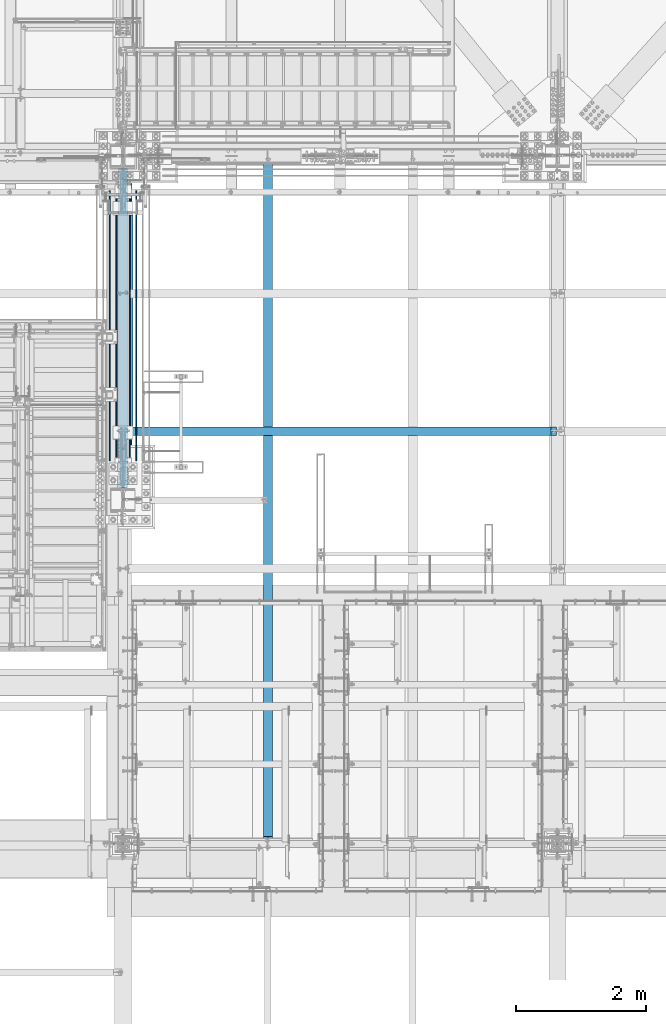
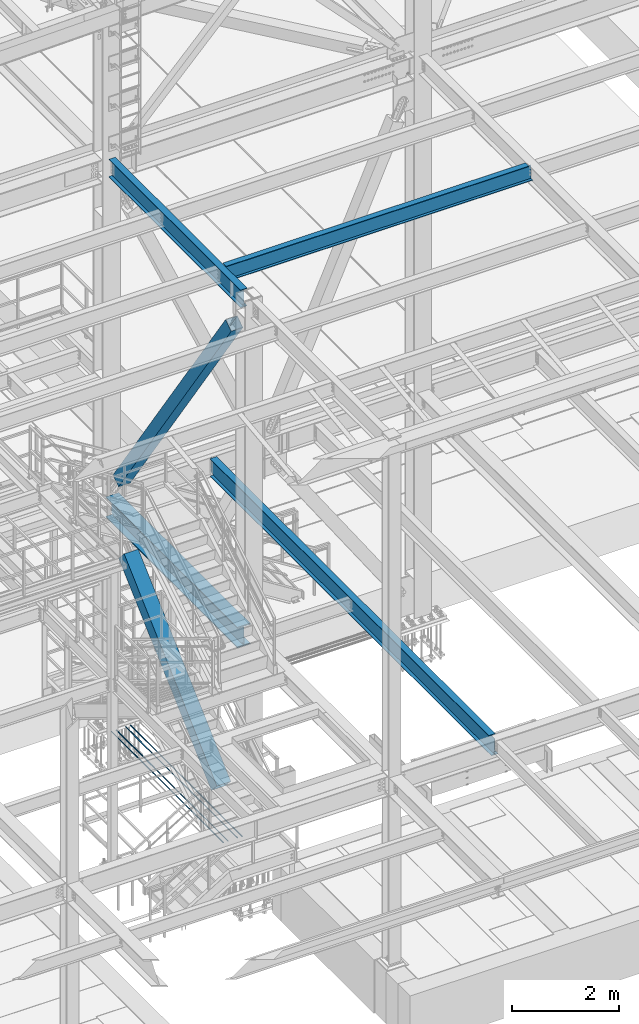
# One storey, part 1777 of 3843: 8 beams, 2 members, 10 elements without a shape of their own.
"""IFC2X3 building model written with IfcOpenShell, lengths in millimetres."""

from ifc_helpers import new_model, si_unit, frame, origin_with_axes, place, context, subcontext, project, spatial, faceted_brep, material, type_object, element, aggregate, save


model = new_model("IFC2X3")

# Units and contexts
model_context = context("Model", 3, precision=1e-05, world=origin_with_axes())
body_context = subcontext(model_context, "Body", "Model", "MODEL_VIEW")
ifc_project = project(units=[si_unit("LENGTHUNIT", "METRE", prefix="MILLI"), si_unit("AREAUNIT", "SQUARE_METRE"), si_unit("VOLUMEUNIT", "CUBIC_METRE"), si_unit("MASSUNIT", "GRAM", prefix="KILO"), si_unit("TIMEUNIT", "SECOND"), si_unit("PLANEANGLEUNIT", "RADIAN"), si_unit("SOLIDANGLEUNIT", "STERADIAN"), si_unit("THERMODYNAMICTEMPERATUREUNIT", "DEGREE_CELSIUS"), si_unit("LUMINOUSINTENSITYUNIT", "LUMEN")], contexts=[model_context])

# Site, building, storey
site_placement = place(None, origin_with_axes())
site = spatial("IfcSite", under=ifc_project, at=site_placement, CompositionType="ELEMENT")
building_placement = place(site_placement, origin_with_axes())
building = spatial("IfcBuilding", under=site, at=building_placement, Name="Undefined", CompositionType="ELEMENT")
storey_placement = place(building_placement, origin_with_axes())
storey = spatial("IfcBuildingStorey", under=building, at=storey_placement, Name="Undefined", CompositionType="ELEMENT", Elevation=0.0)

# Assembly, beam
assembly_1_placement = place(storey_placement, origin_with_axes())
assembly_1 = element("IfcElementAssembly", 1, at=assembly_1_placement, inside=storey, Name="REBAR", AssemblyPlace="NOTDEFINED", PredefinedType="RIGID_FRAME")
ifc_material_1 = material(Name="STEEL/A706-60")
beam_type_1 = type_object("IfcBeamType", Name="#10 REBAR", PredefinedType="NOTDEFINED")
beam_1_placement = place(assembly_1_placement, frame((55727.6, 25082.5, 29687.8375), z_axis=(0.0, 0.0, 1.0), x_axis=(0.0, -1.0, 0.0)))
beam_1 = element("IfcBeam", 2, at=beam_1_placement, type_object=beam_type_1, material=ifc_material_1, Name="REBAR", ObjectType="#10 REBAR", context=body_context, shape_type="Brep", body=[
    faceted_brep([(0.0, -7.9375, 0.0), (0.0, -5.61266007566883, -5.61266007566883), (4165.68743163327, -5.61266007566883, -5.61266007566883), (4165.68743163327, -7.9375, 0.0), (0.0, 0.0, -7.9375), (4165.68743163327, 0.0, -7.9375), (0.0, 5.61266007566883, -5.61266007566883), (4165.68743163327, 5.61266007566883, -5.61266007566883), (0.0, 7.9375, 0.0), (4165.68743163327, 7.9375, 0.0), (0.0, 5.61266007566883, 5.61266007566883), (4165.68743163327, 5.61266007566883, 5.61266007566883), (0.0, 0.0, 7.9375), (4165.68743163327, 0.0, 7.9375), (0.0, -5.61266007566883, 5.61266007566883), (4165.68743163327, -5.61266007566883, 5.61266007566883)], [[[0, 1, 2, 3]], [[1, 4, 5, 2]], [[4, 6, 7, 5]], [[6, 8, 9, 7]], [[8, 10, 11, 9]], [[10, 12, 13, 11]], [[12, 14, 15, 13]], [[14, 0, 3, 15]], [[5, 7, 9, 11, 13, 15, 3, 2]], [[14, 12, 10, 8, 6, 4, 1, 0]]]),
])
aggregate(assembly_1, [beam_1])

assembly_2_placement = place(storey_placement, origin_with_axes())
assembly_2 = element("IfcElementAssembly", 3, at=assembly_2_placement, inside=storey, Name="REBAR", AssemblyPlace="NOTDEFINED", PredefinedType="RIGID_FRAME")
beam_2_placement = place(assembly_2_placement, frame((55829.2, 25082.5, 29687.8375), z_axis=(0.0, 0.0, 1.0), x_axis=(0.0, -1.0, 0.0)))
beam_2 = element("IfcBeam", 4, at=beam_2_placement, type_object=beam_type_1, material=ifc_material_1, Name="REBAR", ObjectType="#10 REBAR", context=body_context, shape_type="Brep", body=[
    faceted_brep([(0.0, -7.9375, 0.0), (0.0, -5.61266007566883, -5.61266007566883), (4165.68743163327, -5.61266007566883, -5.61266007566883), (4165.68743163327, -7.9375, 0.0), (0.0, 0.0, -7.9375), (4165.68743163327, 0.0, -7.9375), (0.0, 5.61266007566883, -5.61266007566883), (4165.68743163327, 5.61266007566883, -5.61266007566883), (0.0, 7.9375, 0.0), (4165.68743163327, 7.9375, 0.0), (0.0, 5.61266007566883, 5.61266007566883), (4165.68743163327, 5.61266007566883, 5.61266007566883), (0.0, 0.0, 7.9375), (4165.68743163327, 0.0, 7.9375), (0.0, -5.61266007566883, 5.61266007566883), (4165.68743163327, -5.61266007566883, 5.61266007566883)], [[[0, 1, 2, 3]], [[1, 4, 5, 2]], [[4, 6, 7, 5]], [[6, 8, 9, 7]], [[8, 10, 11, 9]], [[10, 12, 13, 11]], [[12, 14, 15, 13]], [[14, 0, 3, 15]], [[5, 7, 9, 11, 13, 15, 3, 2]], [[14, 12, 10, 8, 6, 4, 1, 0]]]),
])
aggregate(assembly_2, [beam_2])

assembly_3_placement = place(storey_placement, origin_with_axes())
assembly_3 = element("IfcElementAssembly", 5, at=assembly_3_placement, inside=storey, Name="REBAR", AssemblyPlace="NOTDEFINED", PredefinedType="RIGID_FRAME")
beam_3_placement = place(assembly_3_placement, frame((56032.4, 25082.5, 29687.8375), z_axis=(0.0, 0.0, 1.0), x_axis=(0.0, -1.0, 0.0)))
beam_3 = element("IfcBeam", 6, at=beam_3_placement, type_object=beam_type_1, material=ifc_material_1, Name="REBAR", ObjectType="#10 REBAR", context=body_context, shape_type="Brep", body=[
    faceted_brep([(0.0, -7.9375, 0.0), (0.0, -5.61266007566883, -5.61266007566883), (4165.68743163327, -5.61266007566883, -5.61266007566883), (4165.68743163327, -7.9375, 0.0), (0.0, 0.0, -7.9375), (4165.68743163327, 0.0, -7.9375), (0.0, 5.61266007566883, -5.61266007566883), (4165.68743163327, 5.61266007566883, -5.61266007566883), (0.0, 7.9375, 0.0), (4165.68743163327, 7.9375, 0.0), (0.0, 5.61266007566883, 5.61266007566883), (4165.68743163327, 5.61266007566883, 5.61266007566883), (0.0, 0.0, 7.9375), (4165.68743163327, 0.0, 7.9375), (0.0, -5.61266007566883, 5.61266007566883), (4165.68743163327, -5.61266007566883, 5.61266007566883)], [[[0, 1, 2, 3]], [[1, 4, 5, 2]], [[4, 6, 7, 5]], [[6, 8, 9, 7]], [[8, 10, 11, 9]], [[10, 12, 13, 11]], [[12, 14, 15, 13]], [[14, 0, 3, 15]], [[5, 7, 9, 11, 13, 15, 3, 2]], [[14, 12, 10, 8, 6, 4, 1, 0]]]),
])
aggregate(assembly_3, [beam_3])

assembly_4_placement = place(storey_placement, origin_with_axes())
assembly_4 = element("IfcElementAssembly", 7, at=assembly_4_placement, inside=storey, Name="REBAR", AssemblyPlace="NOTDEFINED", PredefinedType="RIGID_FRAME")
beam_4_placement = place(assembly_4_placement, frame((56134.0, 25082.5, 29687.8375), z_axis=(0.0, 0.0, 1.0), x_axis=(0.0, -1.0, 0.0)))
beam_4 = element("IfcBeam", 8, at=beam_4_placement, type_object=beam_type_1, material=ifc_material_1, Name="REBAR", ObjectType="#10 REBAR", context=body_context, shape_type="Brep", body=[
    faceted_brep([(0.0, -7.9375, 0.0), (0.0, -5.61266007566883, -5.61266007566883), (4165.68743163327, -5.61266007566883, -5.61266007566883), (4165.68743163327, -7.9375, 0.0), (0.0, 0.0, -7.9375), (4165.68743163327, 0.0, -7.9375), (0.0, 5.61266007566883, -5.61266007566883), (4165.68743163327, 5.61266007566883, -5.61266007566883), (0.0, 7.9375, 0.0), (4165.68743163327, 7.9375, 0.0), (0.0, 5.61266007566883, 5.61266007566883), (4165.68743163327, 5.61266007566883, 5.61266007566883), (0.0, 0.0, 7.9375), (4165.68743163327, 0.0, 7.9375), (0.0, -5.61266007566883, 5.61266007566883), (4165.68743163327, -5.61266007566883, 5.61266007566883)], [[[0, 1, 2, 3]], [[1, 4, 5, 2]], [[4, 6, 7, 5]], [[6, 8, 9, 7]], [[8, 10, 11, 9]], [[10, 12, 13, 11]], [[12, 14, 15, 13]], [[14, 0, 3, 15]], [[5, 7, 9, 11, 13, 15, 3, 2]], [[14, 12, 10, 8, 6, 4, 1, 0]]]),
])
aggregate(assembly_4, [beam_4])

# Assembly, member
assembly_5_placement = place(storey_placement, origin_with_axes())
assembly_5 = element("IfcElementAssembly", 9, at=assembly_5_placement, inside=storey, Name="None", AssemblyPlace="NOTDEFINED", PredefinedType="RIGID_FRAME")
ifc_material_2 = material(Name="STEEL/A992")
member_type_1 = type_object("IfcMemberType", Name="HSS10X10X1/4", PredefinedType="NOTDEFINED")
member_1_placement = place(assembly_5_placement, frame((55930.8, 25062.0648839254, 35381.0757645592), z_axis=(-1.0, 0.0, 0.0), x_axis=(0.0, -0.56819627680556, 0.82289306171841)))
member_1 = element("IfcMember", 10, at=member_1_placement, type_object=member_type_1, material=ifc_material_2, Name="None", ObjectType="HSS10X10X1/4", context=body_context, shape_type="Brep", body=[
    faceted_brep([(2.00088834390044e-10, 120.650000000089, -120.649999999994), (-2.03726813197136e-10, -120.650000000081, -120.649999999994), (7397.75000004993, -120.650000005451, -120.650000000001), (7397.7500000501, 120.649999994785, -120.650000000001), (-2.03726813197136e-10, -120.650000000081, 120.649999999994), (7397.75000004993, -120.650000005451, 120.650000000001), (2.00088834390044e-10, 120.650000000089, 120.649999999994), (7397.7500000501, 120.649999994785, 120.650000000001), (2.16459739021957e-10, 127.000000000087, -127.0), (2.16459739021957e-10, 127.000000000087, 127.0), (7397.75000005011, 126.99999999479, 127.0), (7397.75000005011, 126.99999999479, -127.0), (-2.14640749618411e-10, -127.00000000008, 127.0), (7397.75000004992, -127.000000005457, 127.0), (-2.14640749618411e-10, -127.00000000008, -127.0), (7397.75000004992, -127.000000005457, -127.0)], [[[0, 1, 2, 3]], [[1, 4, 5, 2]], [[4, 6, 7, 5]], [[6, 0, 3, 7]], [[8, 9, 10, 11]], [[9, 12, 13, 10]], [[12, 14, 15, 13]], [[14, 8, 11, 15]], [[13, 15, 11, 10], [5, 7, 3, 2]], [[14, 12, 9, 8], [6, 4, 1, 0]]]),
])
aggregate(assembly_5, [member_1])

assembly_6_placement = place(storey_placement, origin_with_axes())
assembly_6 = element("IfcElementAssembly", 11, at=assembly_6_placement, inside=storey, Name="None", AssemblyPlace="NOTDEFINED", PredefinedType="RIGID_FRAME")
member_type_2 = type_object("IfcMemberType", Name="HSS12X12X5/16", PredefinedType="NOTDEFINED")
member_2_placement = place(assembly_6_placement, frame((55930.8, 21350.2654710936, 30642.4085073554), z_axis=(1.0, 0.0, 0.0), x_axis=(0.0, 0.734883807073284, 0.678193033067634)))
member_2 = element("IfcMember", 12, at=member_2_placement, type_object=member_type_2, material=ifc_material_2, Name="None", ObjectType="HSS12X12X5/16", context=body_context, shape_type="Brep", body=[
    faceted_brep([(-2.61934474110603e-10, 144.462500000002, -144.462500000001), (2.61934474110603e-10, -144.462499999993, -144.462500000001), (4705.34999999976, -144.462499991408, -144.462500000001), (4705.34999999923, 144.462500008588, -144.462500000001), (2.61934474110603e-10, -144.462499999993, 144.462500000001), (4705.34999999976, -144.462499991408, 144.462500000001), (-2.61934474110603e-10, 144.462500000002, 144.462500000001), (4705.34999999923, 144.462500008588, 144.462500000001), (-2.7648638933897e-10, 152.400000000002, -152.400000000001), (-2.7648638933897e-10, 152.400000000002, 152.400000000001), (4705.34999999922, 152.400000008588, 152.400000000001), (4705.34999999922, 152.400000008588, -152.400000000001), (2.83762346953154e-10, -152.399999999993, 152.400000000001), (4705.34999999978, -152.399999991404, 152.400000000001), (2.83762346953154e-10, -152.399999999993, -152.400000000001), (4705.34999999978, -152.399999991404, -152.400000000001)], [[[0, 1, 2, 3]], [[1, 4, 5, 2]], [[4, 6, 7, 5]], [[6, 0, 3, 7]], [[8, 9, 10, 11]], [[9, 12, 13, 10]], [[12, 14, 15, 13]], [[14, 8, 11, 15]], [[13, 15, 11, 10], [5, 7, 3, 2]], [[14, 12, 9, 8], [6, 4, 1, 0]]]),
])
aggregate(assembly_6, [member_2])

# Assembly, beam
assembly_7_placement = place(storey_placement, origin_with_axes())
assembly_7 = element("IfcElementAssembly", 13, at=assembly_7_placement, inside=storey, Name="BEAM", AssemblyPlace="NOTDEFINED", PredefinedType="RIGID_FRAME")
beam_type_2 = type_object("IfcBeamType", Name="W14X26", PredefinedType="NOTDEFINED")
beam_5_placement = place(assembly_7_placement, frame((55930.8, 21369.02, 42292.5875), z_axis=(0.0, 0.0, 1.0), x_axis=(1.0, 0.0, 0.0)))
beam_5 = element("IfcBeam", 14, at=beam_5_placement, type_object=beam_type_2, material=ifc_material_2, Name="BEAM", ObjectType="W14X26", context=body_context, shape_type="Brep", body=[
    faceted_brep([(6602.41249847413, -63.5, 176.212500000001), (6602.41249847413, -63.5, 165.099999999999), (6602.41249847413, -3.17499999999927, 165.099999999999), (6602.41249847413, -3.17499999999927, 153.987499809264), (6602.41249847413, 3.17499999999927, 153.987499809264), (6602.41249847413, 3.17499999999927, 165.099999999999), (6602.41249847413, 63.5, 165.099999999999), (6602.41249847413, 63.5, 176.212500000001), (6603.37922839671, -3.17499999999927, 149.127420291217), (6603.37922839671, 3.17499999999927, 149.127420291217), (6606.13224229719, -3.17499999999927, 145.007243823064), (6606.13224229719, 3.17499999999927, 145.007243823064), (6610.25241876535, -3.17499999999927, 142.25422992259), (6610.25241876535, 3.17499999999927, 142.25422992259), (6615.11249828339, -3.17499999999927, 141.287499999999), (6615.11249828339, 3.17499999999927, 141.287499999999), (6687.34375, -3.17499999999927, 141.287499999999), (6687.34375, 3.17499999999927, 141.287499999999), (82.5500030517651, -63.5, 176.212500000001), (82.5500030517651, 63.5, 176.212500000001), (82.5500030517651, 63.5, 165.099999999999), (82.5500030517651, 3.17499999999927, 165.099999999999), (82.5500030517651, 3.17499999999927, 160.33749980927), (82.5500030517651, -3.17499999999927, 160.33749980927), (82.5500030517651, -3.17499999999927, 165.099999999999), (82.5500030517651, -63.5, 165.099999999999), (81.5832731291739, 3.17499999999927, 155.477420291223), (81.5832731291739, -3.17499999999927, 155.477420291223), (78.8302592287, 3.17499999999927, 151.357243823069), (78.8302592287, -3.17499999999927, 151.357243823069), (74.7100827605464, 3.17499999999927, 148.604229922596), (74.7100827605464, -3.17499999999927, 148.604229922596), (69.8500032425, 3.17499999999927, 147.637500000004), (69.8500032425, -3.17499999999927, 147.637500000004), (15.875, 3.17499999999927, 147.637500000004), (15.875, -3.17499999999927, 147.637500000004), (15.875, 3.17499999999927, 125.412499999999), (15.875, 3.17499999999927, -105.1875), (15.875, 3.17499999999927, -165.099999999999), (15.875, 63.5, -165.099999999999), (15.875, 63.5, -176.212500000001), (15.875, -63.5, -176.212500000001), (15.875, -63.5, -165.099999999999), (15.875, -3.17499999999927, -165.099999999999), (6687.34375, 3.17499999999927, -165.099999999999), (6687.34375, 63.5, -165.099999999999), (6687.34375, 63.5, -176.212500000001), (6687.34375, -63.5, -176.212500000001), (6687.34375, -63.5, -165.099999999999), (6687.34375, -3.17499999999927, -165.099999999999), (6687.34375, 3.17499999999927, 125.412499999999), (6687.34375, 3.17499999999927, -105.187499999993)], [[[0, 1, 2, 3, 4, 5, 6, 7]], [[8, 9, 4, 3]], [[10, 11, 9, 8]], [[12, 13, 11, 10]], [[14, 15, 13, 12]], [[16, 17, 15, 14]], [[18, 19, 20, 21, 22, 23, 24, 25]], [[23, 22, 26, 27]], [[27, 26, 28, 29]], [[29, 28, 30, 31]], [[31, 30, 32, 33]], [[33, 32, 34, 35]], [[36, 37, 38, 39, 40, 41, 42, 43, 35, 34]], [[39, 38, 44, 45]], [[40, 39, 45, 46]], [[41, 40, 46, 47]], [[42, 41, 47, 48]], [[43, 42, 48, 49]], [[12, 10, 8, 3, 2, 24, 23, 27, 29, 31, 33, 35, 43, 49, 16, 14]], [[25, 24, 2, 1]], [[18, 25, 1, 0]], [[19, 18, 0, 7]], [[20, 19, 7, 6]], [[21, 20, 6, 5]], [[50, 51, 44, 38, 37, 36, 34, 32, 30, 28, 26, 22, 21, 5, 4, 9, 11, 13, 15, 17]], [[49, 48, 47, 46, 45, 44, 51, 50, 17, 16]]]),
])
aggregate(assembly_7, [beam_5])

assembly_8_placement = place(storey_placement, origin_with_axes())
assembly_8 = element("IfcElementAssembly", 15, at=assembly_8_placement, inside=storey, Name="BEAM", AssemblyPlace="NOTDEFINED", PredefinedType="RIGID_FRAME")
beam_type_3 = type_object("IfcBeamType", Name="W16X31", PredefinedType="NOTDEFINED")
beam_6_placement = place(assembly_8_placement, frame((55930.8, 20307.3, 42267.1875), z_axis=(0.0, 0.0, 1.0), x_axis=(0.0, 1.0, 0.0)))
beam_6 = element("IfcBeam", 16, at=beam_6_placement, type_object=beam_type_3, material=ifc_material_2, Name="BEAM", ObjectType="W16X31", context=body_context, shape_type="Brep", body=[
    faceted_brep([(192.578674208467, -3.17500000001746, 161.925000000003), (188.912500000002, 3.17500000000291, 161.925000000003), (188.912500000002, 3.17500000000291, -161.925000000003), (192.578674208467, -3.17500000000291, -161.925000000003), (226.782686521365, -3.17500000000291, -161.925000000003), (226.782686521365, 3.17500000000291, -161.925000000003), (231.853519336077, 3.17500000000291, -163.38698081053), (231.853519336077, -3.17500000000291, -163.38698081053), (235.367720011072, 3.17500000000291, -167.324127866581), (235.367720011072, -3.17500000000291, -167.324127866581), (236.24650762101, 3.17500000000291, -172.527825173471), (236.24650762101, -3.17500000000291, -172.527825173471), (234.220114045427, 3.17500000000291, -177.400654167177), (234.220114045427, -3.17500000000291, -177.400654167177), (229.910596741691, 3.17500000000291, -180.446765447792), (229.910596741691, -3.17500000000291, -180.446765447792), (202.136500000001, 3.17500000000291, -190.103000000003), (202.136500000001, -3.17500000000291, -190.103000000003), (195.5573118578, 3.17500000000291, -190.103000000003), (195.5573118578, -3.17500000000291, -190.103000000003), (195.328123715604, 3.17500000000291, -190.5), (195.328123715604, 69.8499999999985, -190.5), (188.912500000002, 69.8499999999985, -201.612500000003), (188.912500000002, -69.8499999999985, -201.612500000003), (195.328123715604, -69.8499999999985, -190.5), (195.328123715604, -3.17500000000291, -190.5), (5108.5093762844, 3.17500000000291, -190.5), (5108.5093762844, 69.8499999999985, -190.5), (5114.925, 69.8499999999985, -201.612500000003), (5114.925, -69.8499999999985, -201.612500000003), (5108.5093762844, -69.8499999999985, -190.5), (5108.5093762844, -3.17500000000291, -190.5), (5108.2801881422, 3.17500000000291, -190.103000000003), (5108.2801881422, -3.17500000000291, -190.103000000003), (5101.701, 3.17500000000291, -190.103000000003), (5101.701, -3.17500000000291, -190.103000000003), (5073.92690325831, 3.17500000000291, -180.446765447792), (5073.92690325831, -3.17500000000291, -180.446765447792), (5069.61738595457, 3.17500000000291, -177.400654167177), (5069.61738595457, -3.17500000000291, -177.400654167177), (5067.59099237899, 3.17500000000291, -172.527825173471), (5067.59099237899, -3.17500000000291, -172.527825173471), (5068.46977998893, 3.17500000000291, -167.324127866581), (5068.46977998893, -3.17500000000291, -167.324127866581), (5071.98398066392, 3.17500000000291, -163.38698081053), (5071.98398066392, -3.17500000000291, -163.38698081053), (5077.05481347863, 3.17500000000291, -161.925000000003), (5077.05481347863, -3.17500000000291, -161.925000000003), (5114.925, 3.17500000000291, -161.925000000003), (5111.25882579153, -3.17500000000291, -161.925000000003), (5114.925, 3.17500000001019, 161.925000000003), (5111.25882579153, -3.17500000000291, 161.925000000003), (5077.57881347863, 3.17500000000291, 161.925000000003), (5077.57881347863, -3.17500000000291, 161.925000000003), (5072.50798066392, 3.17500000000291, 163.38698081053), (5072.50798066392, -3.17500000000291, 163.38698081053), (5068.99377998892, 3.17500000000291, 167.324127866581), (5068.99377998892, -3.17500000000291, 167.324127866581), (5068.11499237899, 3.17500000000291, 172.527825173471), (5068.11499237899, -3.17500000000291, 172.527825173471), (5070.14138595457, 3.17500000000291, 177.400654167177), (5070.14138595457, -3.17500000000291, 177.400654167177), (5074.45090325831, 3.17500000000291, 180.446765447792), (5074.45090325831, -3.17500000000291, 180.446765447792), (5102.22499999999, 3.17500000000291, 190.103000000003), (5102.22499999999, -3.17500000000291, 190.103000000003), (5114.925, 3.17500000000291, 190.103000000003), (5114.925, -3.17500000000291, 190.103000000003), (5114.925, 3.17500000000291, 190.5), (5114.925, -3.17500000000291, 190.5), (188.912500000002, 3.17500000000291, 190.5), (188.912500000002, 69.8499999999985, 190.5), (5114.925, 69.8499999999985, 190.5), (195.328097701327, 69.8499999999985, 201.612500000003), (5108.50940229867, 69.8499999999985, 201.612500000003), (195.328097701327, -69.8499999999985, 201.612500000003), (188.912500000002, -69.8499999999985, 190.5), (5114.925, -69.8499999999985, 190.5), (5108.50940229867, -69.8499999999985, 201.612500000003), (188.912500000002, -3.17500000000291, 190.5), (188.912500000002, 3.17500000000291, 190.103000000003), (188.912500000002, -3.17500000000291, 190.103000000003), (201.612500000003, 3.17500000000291, 190.103000000003), (201.612500000003, -3.17500000000291, 190.103000000003), (229.38659674169, 3.17500000000291, 180.446765447792), (229.38659674169, -3.17500000000291, 180.446765447792), (233.696114045426, 3.17500000000291, 177.400654167177), (233.696114045426, -3.17500000000291, 177.400654167177), (235.722507621012, 3.17500000000291, 172.527825173471), (235.722507621012, -3.17500000000291, 172.527825173471), (234.843720011075, 3.17500000000291, 167.324127866581), (234.843720011075, -3.17500000000291, 167.324127866581), (231.329519336075, 3.17500000000291, 163.38698081053), (231.329519336075, -3.17500000000291, 163.38698081053), (226.258686521363, 3.17500000000291, 161.925000000003), (226.258686521363, -3.17500000000291, 161.925000000003)], [[[0, 1, 2, 3]], [[4, 5, 6, 7]], [[7, 6, 8, 9]], [[9, 8, 10, 11]], [[11, 10, 12, 13]], [[13, 12, 14, 15]], [[15, 14, 16, 17]], [[17, 16, 18, 19]], [[19, 18, 20, 21, 22, 23, 24, 25]], [[21, 20, 26, 27]], [[22, 21, 27, 28]], [[23, 22, 28, 29]], [[24, 23, 29, 30]], [[25, 24, 30, 31]], [[29, 28, 27, 26, 32, 33, 31, 30]], [[34, 35, 33, 32]], [[35, 34, 36, 37]], [[37, 36, 38, 39]], [[39, 38, 40, 41]], [[41, 40, 42, 43]], [[43, 42, 44, 45]], [[45, 44, 46, 47]], [[47, 46, 48, 49]], [[50, 51, 49, 48]], [[52, 53, 51, 50]], [[53, 52, 54, 55]], [[55, 54, 56, 57]], [[57, 56, 58, 59]], [[59, 58, 60, 61]], [[61, 60, 62, 63]], [[63, 62, 64, 65]], [[65, 64, 66, 67]], [[67, 66, 68, 69]], [[70, 71, 72, 68]], [[71, 73, 74, 72]], [[75, 76, 77, 78]], [[73, 75, 78, 74]], [[77, 69, 68, 72, 74, 78]], [[76, 79, 69, 77]], [[75, 73, 71, 70, 79, 76]], [[80, 81, 79, 70]], [[82, 83, 81, 80]], [[83, 82, 84, 85]], [[85, 84, 86, 87]], [[87, 86, 88, 89]], [[89, 88, 90, 91]], [[91, 90, 92, 93]], [[93, 92, 94, 95]], [[4, 7, 9, 11, 13, 15, 17, 19, 25, 31, 33, 35, 37, 39, 41, 43, 45, 47, 49, 51, 53, 55, 57, 59, 61, 63, 65, 67, 69, 79, 81, 83, 85, 87, 89, 91, 93, 95, 0, 3]], [[5, 4, 3, 2]], [[94, 92, 90, 88, 86, 84, 82, 80, 70, 68, 66, 64, 62, 60, 58, 56, 54, 52, 50, 48, 46, 44, 42, 40, 38, 36, 34, 32, 26, 20, 18, 16, 14, 12, 10, 8, 6, 5, 2, 1]], [[95, 94, 1, 0]]]),
])
aggregate(assembly_8, [beam_6])

assembly_9_placement = place(storey_placement, origin_with_axes())
assembly_9 = element("IfcElementAssembly", 17, at=assembly_9_placement, inside=storey, Name="BEAM", AssemblyPlace="NOTDEFINED", PredefinedType="RIGID_FRAME")
beam_7_placement = place(assembly_9_placement, frame((58166.0, 14998.7, 34609.0875), z_axis=(0.0, 0.0, 1.0), x_axis=(0.0, 1.0, 0.0)))
beam_7 = element("IfcBeam", 18, at=beam_7_placement, type_object=beam_type_3, material=ifc_material_2, Name="BEAM", ObjectType="W16X31", context=body_context, shape_type="Brep", body=[
    faceted_brep([(10511.63125, -3.17500000000291, -190.5), (10511.63125, -69.8499999999985, -190.5), (10511.63125, -69.8499999999985, -201.612500000003), (10511.63125, 69.8499999999985, -201.612500000003), (10511.63125, 69.8499999999985, -190.5), (10511.63125, 3.17500000000291, -190.5), (10511.63125, 3.17500000000291, -188.912499809259), (10511.63125, -3.17500000000291, -188.912499809259), (10512.5979799226, 3.17500000000291, -184.052420291213), (10512.5979799226, -3.17500000000291, -184.052420291213), (10515.3509938231, 3.17500000000291, -179.932243823059), (10515.3509938231, -3.17500000000291, -179.932243823059), (10519.4711702912, 3.17500000000291, -177.179229922585), (10519.4711702912, -3.17500000000291, -177.179229922585), (10524.3312498093, 3.17500000000291, -176.212499999994), (10524.3312498093, -3.17500000000291, -176.212499999994), (10600.53125, -3.17500000000291, -176.212499999994), (10600.53125, 3.17500000000291, -176.212499999994), (113.506249337661, 3.17500000000291, 190.5), (113.506249337661, 69.8500000000058, 190.5), (10511.63125, 69.8499999999985, 190.5), (10511.63125, 3.17500000000291, 190.5), (18.2562500000004, 3.17500000000291, 163.512499999997), (18.2562500000004, 3.17500000000291, -143.287499999999), (18.2562500000004, 3.17500000000291, -190.5), (18.2562500000004, 69.8500000000058, -190.5), (18.2562500000004, 69.8500000000058, -201.612500000003), (18.2562500000004, -69.8500000000058, -201.612500000003), (18.2562500000004, -69.8500000000058, -190.5), (18.2562500000004, -3.17500000000291, -190.5), (18.2562500000004, -3.17500000000291, 169.86250000001), (18.2562500000004, 3.17500000000291, 169.86250000001), (100.806249528396, -3.17500000000291, 169.86250000001), (100.806249528396, 3.17500000000291, 169.86250000001), (105.666329046442, -3.17500000000291, 170.829229922601), (105.666329046442, 3.17500000000291, 170.829229922601), (109.786505514596, -3.17500000000291, 173.582243823075), (109.786505514596, 3.17500000000291, 173.582243823075), (112.539519415073, -3.17500000000291, 177.702420291229), (112.539519415073, 3.17500000000291, 177.702420291229), (113.506249337661, -3.17500000000291, 182.562499809275), (113.506249337661, 3.17500000000291, 182.562499809275), (113.506249337661, -69.8500000000058, 201.612500000003), (113.506249337661, 69.8500000000058, 201.612500000003), (113.506249337661, -3.17500000000291, 190.5), (113.506249337661, -69.8500000000058, 190.5), (10511.63125, -3.17500000000291, 190.5), (10511.63125, -69.8499999999985, 190.5), (10511.63125, -69.8499999999985, 201.612500000003), (10511.63125, 69.8499999999985, 201.612500000003), (10511.63125, -3.17500000000291, 188.912499809274), (10511.63125, 3.17500000000291, 188.912499809274), (10512.5979799226, -3.17500000000291, 184.052420291227), (10512.5979799226, 3.17500000000291, 184.052420291227), (10515.3509938231, -3.17500000000291, 179.932243823074), (10515.3509938231, 3.17500000000291, 179.932243823074), (10519.4711702912, -3.17500000000291, 177.1792299226), (10519.4711702912, 3.17500000000291, 177.1792299226), (10524.3312498093, -3.17500000000291, 176.212500000009), (10524.3312498093, 3.17500000000291, 176.212500000009), (10600.53125, -3.17500000000291, 176.212500000009), (10600.53125, 3.17500000000291, 176.212500000009)], [[[0, 1, 2, 3, 4, 5, 6, 7]], [[7, 6, 8, 9]], [[9, 8, 10, 11]], [[11, 10, 12, 13]], [[13, 12, 14, 15]], [[16, 15, 14, 17]], [[18, 19, 20, 21]], [[22, 23, 24, 25, 26, 27, 28, 29, 30, 31]], [[32, 33, 31, 30]], [[34, 35, 33, 32]], [[36, 37, 35, 34]], [[38, 39, 37, 36]], [[40, 41, 39, 38]], [[42, 43, 19, 18, 41, 40, 44, 45]], [[45, 44, 46, 47]], [[42, 45, 47, 48]], [[43, 42, 48, 49]], [[19, 43, 49, 20]], [[48, 47, 46, 50, 51, 21, 20, 49]], [[52, 53, 51, 50]], [[54, 55, 53, 52]], [[56, 57, 55, 54]], [[58, 59, 57, 56]], [[60, 61, 59, 58]], [[61, 60, 16, 17]], [[12, 10, 8, 6, 5, 24, 23, 22, 31, 33, 35, 37, 39, 41, 18, 21, 51, 53, 55, 57, 59, 61, 17, 14]], [[25, 24, 5, 4]], [[26, 25, 4, 3]], [[27, 26, 3, 2]], [[28, 27, 2, 1]], [[29, 28, 1, 0]], [[60, 58, 56, 54, 52, 50, 46, 44, 40, 38, 36, 34, 32, 30, 29, 0, 7, 9, 11, 13, 15, 16]]]),
])
aggregate(assembly_9, [beam_7])

assembly_10_placement = place(storey_placement, origin_with_axes())
assembly_10 = element("IfcElementAssembly", 19, at=assembly_10_placement, inside=storey, Name="BEAM", AssemblyPlace="NOTDEFINED", PredefinedType="RIGID_FRAME")
beam_type_4 = type_object("IfcBeamType", Name="W18X76", PredefinedType="NOTDEFINED")
beam_8_placement = place(assembly_10_placement, frame((55930.8, 20307.3, 34578.925), z_axis=(0.0, 0.0, 1.0), x_axis=(0.0, 1.0, 0.0)))
beam_8 = element("IfcBeam", 20, at=beam_8_placement, type_object=beam_type_4, material=ifc_material_2, Name="BEAM", ObjectType="W18X76", context=body_context, shape_type="Brep", body=[
    faceted_brep([(195.328304864754, -5.55624999999418, 185.737500000003), (188.912500000002, 5.55625000000146, 185.737500000003), (188.912500000002, 5.55625000000146, -185.737500000003), (195.328304864754, -5.55625000000146, -185.737500000003), (253.903709297476, -5.55625000000146, -185.737500000003), (253.903709297476, 5.55625000000146, -185.737500000003), (259.161168169587, 5.55625000000146, -187.319909112848), (259.161168169587, -5.55625000000146, -187.319909112848), (262.671760655809, 5.55625000000146, -191.541358246504), (262.671760655809, -5.55625000000146, -191.541358246504), (263.269041871274, 5.55625000000146, -196.999210162961), (263.269041871274, -5.55625000000146, -196.999210162961), (260.754556534906, 5.55625000000146, -201.880015002906), (260.754556534906, -5.55625000000146, -201.880015002906), (255.963778593108, 5.55625000000146, -204.562055104157), (255.963778593108, -5.55625000000146, -204.562055104157), (213.740500000004, 5.55625000000146, -213.915500000003), (213.740500000004, -5.55625000000146, -213.915500000003), (199.223308850163, 5.55625000000146, -213.915500000003), (199.223308850163, -5.55625000000146, -213.915500000003), (5104.84338229967, 5.55625000000146, -214.3125), (5104.84338229967, 139.699999999997, -214.3125), (198.994117700327, 139.699999999997, -214.3125), (198.994117700327, 5.55625000000146, -214.3125), (5114.925, 139.699999999997, -231.775000000001), (188.912500000002, 139.699999999997, -231.775000000001), (5114.925, -139.699999999997, -231.775000000001), (188.912500000002, -139.699999999997, -231.775000000001), (5104.84338229967, -139.699999999997, -214.3125), (198.994117700327, -139.699999999997, -214.3125), (198.994117700327, -5.55625000000146, -214.3125), (5104.84338229967, -5.55625000000146, -214.3125), (5104.61419114983, 5.55625000000146, -213.915500000003), (5104.61419114983, -5.55625000000146, -213.915500000003), (5090.09699999999, 5.55625000000146, -213.915500000003), (5090.09699999999, -5.55625000000146, -213.915500000003), (5047.87372140689, 5.55625000000146, -204.562055104157), (5047.87372140689, -5.55625000000146, -204.562055104157), (5043.08294346509, 5.55625000000146, -201.880015002906), (5043.08294346509, -5.55625000000146, -201.880015002906), (5040.56845812872, 5.55625000000146, -196.999210162961), (5040.56845812872, -5.55625000000146, -196.999210162961), (5041.16573934419, 5.55625000000146, -191.541358246504), (5041.16573934419, -5.55625000000146, -191.541358246504), (5044.67633183041, 5.55625000000146, -187.319909112848), (5044.67633183041, -5.55625000000146, -187.319909112848), (5049.93379070252, 5.55625000000146, -185.737500000003), (5049.93379070252, -5.55625000000146, -185.737500000003), (5114.925, 5.55625000000146, -185.737500000003), (5108.50919513523, -5.55625000000146, -185.737500000003), (5114.92499999998, 5.55625000000873, 185.737500000003), (5108.50919513523, -5.55625000000146, 185.737500000003), (5049.36179070252, 5.55625000000146, 185.737500000003), (5049.36179070252, -5.55625000000146, 185.737500000003), (5044.10433183041, 5.55625000000146, 187.319909112848), (5044.10433183041, -5.55625000000146, 187.319909112848), (5040.59373934419, 5.55625000000146, 191.541358246504), (5040.59373934419, -5.55625000000146, 191.541358246504), (5039.99645812872, 5.55625000000146, 196.999210162961), (5039.99645812872, -5.55625000000146, 196.999210162961), (5042.51094346509, 5.55625000000146, 201.880015002906), (5042.51094346509, -5.55625000000146, 201.880015002906), (5047.30172140689, 5.55625000000146, 204.562055104157), (5047.30172140689, -5.55625000000146, 204.562055104157), (5089.52499999999, 5.55625000000146, 213.915500000003), (5089.52499999999, -5.55625000000146, 213.915500000003), (5114.925, 5.55625000000146, 213.915500000003), (5114.925, -5.55625000000146, 213.915500000003), (5114.925, 5.55625000000146, 214.3125), (5114.925, -5.55625000000146, 214.3125), (5114.925, -139.699999999997, 214.3125), (5114.925, 139.699999999997, 214.3125), (5104.84339964275, 139.699999999997, 231.775000000001), (5104.84339964275, -139.699999999997, 231.775000000001), (188.912500000002, 5.55625000000146, 214.3125), (188.912500000002, 139.699999999997, 214.3125), (198.994100357246, 139.699999999997, 231.775000000001), (198.994100357246, -139.699999999997, 231.775000000001), (188.912500000002, -139.699999999997, 214.3125), (188.912500000002, -5.55625000000146, 214.3125), (188.912500000002, 5.55625000000146, 213.915500000003), (188.912500000002, -5.55625000000146, 213.915500000003), (214.312500000004, 5.55625000000146, 213.915500000003), (214.312500000004, -5.55625000000146, 213.915500000003), (256.535778593108, 5.55625000000146, 204.562055104157), (256.535778593108, -5.55625000000146, 204.562055104157), (261.32655653491, 5.55625000000146, 201.880015002906), (261.32655653491, -5.55625000000146, 201.880015002906), (263.841041871277, 5.55625000000146, 196.999210162961), (263.841041871277, -5.55625000000146, 196.999210162961), (263.243760655809, 5.55625000000146, 191.541358246504), (263.243760655809, -5.55625000000146, 191.541358246504), (259.73316816959, 5.55625000000146, 187.319909112848), (259.73316816959, -5.55625000000146, 187.319909112848), (254.475709297476, 5.55625000000146, 185.737500000003), (254.475709297476, -5.55625000000146, 185.737500000003)], [[[0, 1, 2, 3]], [[4, 5, 6, 7]], [[7, 6, 8, 9]], [[9, 8, 10, 11]], [[11, 10, 12, 13]], [[13, 12, 14, 15]], [[15, 14, 16, 17]], [[17, 16, 18, 19]], [[20, 21, 22, 23]], [[21, 24, 25, 22]], [[24, 26, 27, 25]], [[26, 28, 29, 27]], [[19, 18, 23, 22, 25, 27, 29, 30]], [[28, 31, 30, 29]], [[26, 24, 21, 20, 32, 33, 31, 28]], [[34, 35, 33, 32]], [[35, 34, 36, 37]], [[37, 36, 38, 39]], [[39, 38, 40, 41]], [[41, 40, 42, 43]], [[43, 42, 44, 45]], [[45, 44, 46, 47]], [[47, 46, 48, 49]], [[50, 51, 49, 48]], [[52, 53, 51, 50]], [[53, 52, 54, 55]], [[55, 54, 56, 57]], [[57, 56, 58, 59]], [[59, 58, 60, 61]], [[61, 60, 62, 63]], [[63, 62, 64, 65]], [[65, 64, 66, 67]], [[67, 66, 68, 69]], [[70, 69, 68, 71, 72, 73]], [[71, 68, 74, 75]], [[72, 71, 75, 76]], [[73, 72, 76, 77]], [[70, 73, 77, 78]], [[69, 70, 78, 79]], [[77, 76, 75, 74, 79, 78]], [[80, 81, 79, 74]], [[82, 83, 81, 80]], [[83, 82, 84, 85]], [[85, 84, 86, 87]], [[87, 86, 88, 89]], [[89, 88, 90, 91]], [[91, 90, 92, 93]], [[93, 92, 94, 95]], [[4, 7, 9, 11, 13, 15, 17, 19, 30, 31, 33, 35, 37, 39, 41, 43, 45, 47, 49, 51, 53, 55, 57, 59, 61, 63, 65, 67, 69, 79, 81, 83, 85, 87, 89, 91, 93, 95, 0, 3]], [[5, 4, 3, 2]], [[94, 92, 90, 88, 86, 84, 82, 80, 74, 68, 66, 64, 62, 60, 58, 56, 54, 52, 50, 48, 46, 44, 42, 40, 38, 36, 34, 32, 20, 23, 18, 16, 14, 12, 10, 8, 6, 5, 2, 1]], [[95, 94, 1, 0]]]),
])
aggregate(assembly_10, [beam_8])

save(model, "model.ifc")
